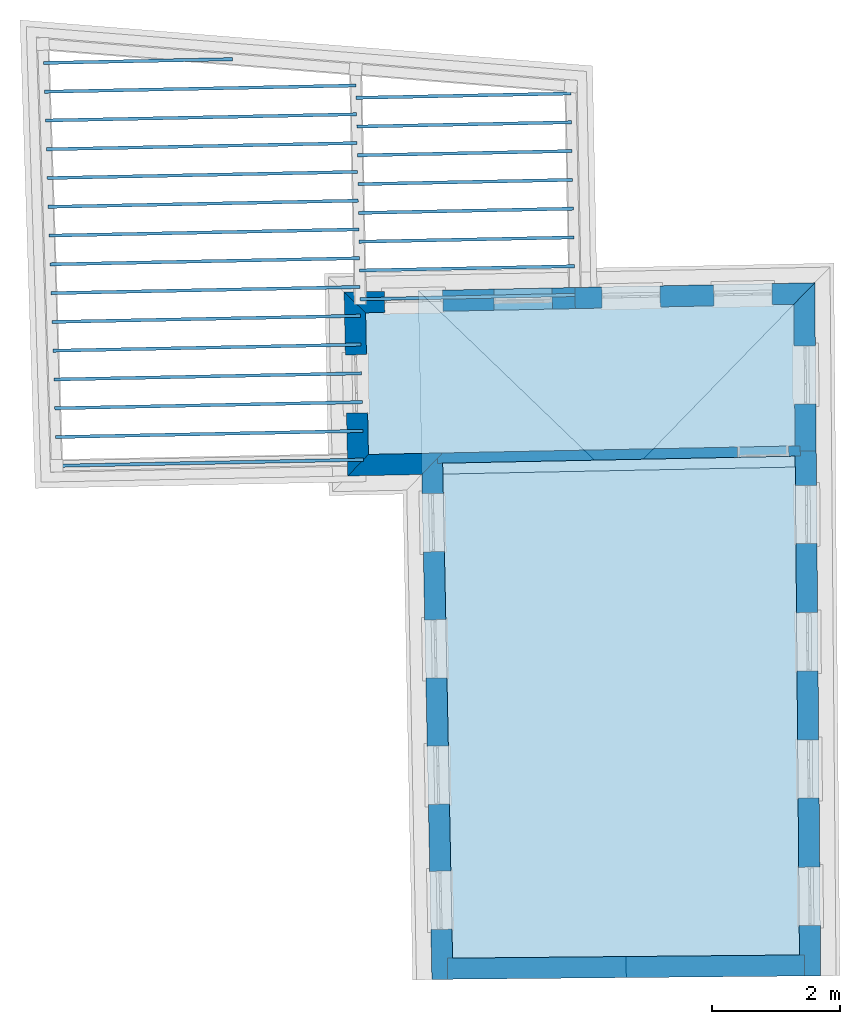
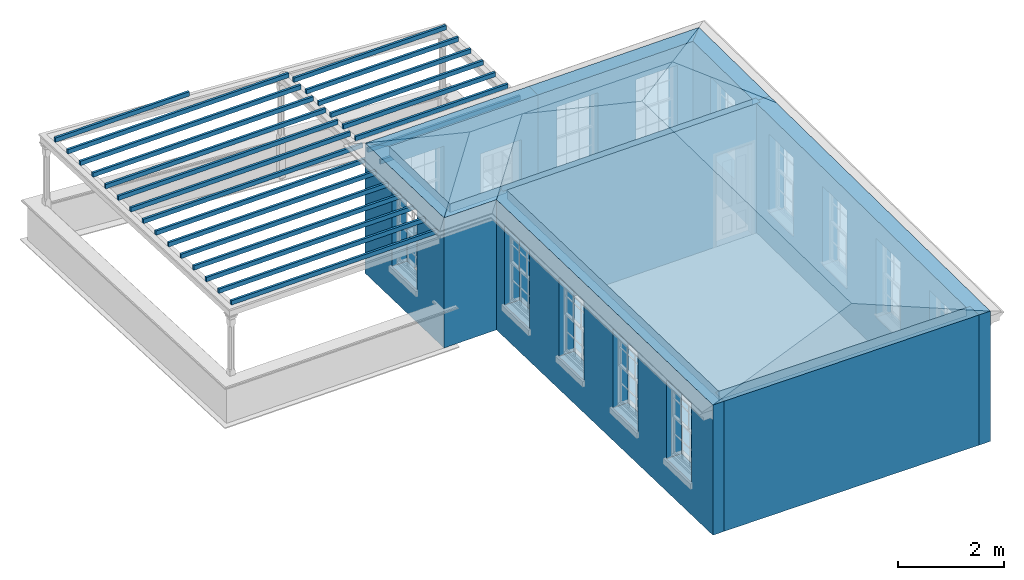
# One storey, part 1 of 11: 26 slabs, 9 walls, 2 roofs, 15 openings.
"""IFC2X3 building model written with IfcOpenShell, lengths in metres."""

from ifc_helpers import new_model, si_unit, frame, origin, place, context, subcontext, project, spatial, polyline, outline, extrude, faceted_brep, material, layer, layer_set, layer_usage, element, save


model = new_model("IFC2X3")

# Units and contexts
model_context = context("Model", 3, world=origin())
body_context = subcontext(model_context, "Body", "Model", "MODEL_VIEW")
ifc_project = project(units=[si_unit("PLANEANGLEUNIT", "RADIAN"), si_unit("MASSUNIT", "GRAM", prefix="KILO"), si_unit("FORCEUNIT", "NEWTON", prefix="KILO"), si_unit("LENGTHUNIT", "METRE")], contexts=[model_context])

# Site, building, storey
site_placement = place(None, origin())
site = spatial("IfcSite", under=ifc_project, at=site_placement, CompositionType="ELEMENT")
building_placement = place(None, origin())
building = spatial("IfcBuilding", under=site, at=building_placement, Name="Building plot-11", CompositionType="ELEMENT")
storey_placement = place(None, frame((0.0, 0.0, 5.3)))
storey = spatial("IfcBuildingStorey", under=building, at=storey_placement, Name="Floor 1", CompositionType="ELEMENT", Elevation=5.3)

# Slabs
slab_1_placement = place(storey_placement, frame((0.0, 0.0, 2.5)))
element("IfcSlab", 1, at=slab_1_placement, inside=storey, Name="Slab", ObjectType="Slab", PredefinedType="FLOOR", context=body_context, shape_type="SweptSolid", body=[
    extrude(outline(polyline([(58.6521226222642, 25.9709667040355), (58.6531222515861, 25.920976697622), (62.0106895836029, 25.9881165720905), (62.009689954281, 26.038106578504), (58.6521226222642, 25.9709667040355)])), origin(), (0.0, 0.0, 1.0), 0.1),
])
slab_2_placement = place(storey_placement, frame((0.0, 0.0, 2.5)))
element("IfcSlab", 2, at=slab_2_placement, inside=storey, Name="Slab", ObjectType="Slab", PredefinedType="FLOOR", context=body_context, shape_type="SweptSolid", body=[
    extrude(outline(polyline([(58.6611192861611, 25.5210566463143), (58.662118915483, 25.4710666399008), (62.0196862474998, 25.5382065143693), (62.018686618178, 25.5881965207827), (58.6611192861611, 25.5210566463143)])), origin(), (0.0, 0.0, 1.0), 0.1),
])
slab_3_placement = place(storey_placement, frame((0.0, 0.0, 2.5)))
element("IfcSlab", 3, at=slab_3_placement, inside=storey, Name="Slab", ObjectType="Slab", PredefinedType="FLOOR", context=body_context, shape_type="SweptSolid", body=[
    extrude(outline(polyline([(58.6701159500581, 25.071146588593), (58.67111557938, 25.0211565821796), (62.0286829113968, 25.088296456648), (62.0276832820749, 25.1382864630615), (58.6701159500581, 25.071146588593)])), origin(), (0.0, 0.0, 1.0), 0.1),
])
slab_4_placement = place(storey_placement, frame((0.0, 0.0, 2.5)))
element("IfcSlab", 4, at=slab_4_placement, inside=storey, Name="Slab", ObjectType="Slab", PredefinedType="FLOOR", context=body_context, shape_type="SweptSolid", body=[
    extrude(outline(polyline([(58.679112613955, 24.6212365308718), (58.6801122432769, 24.5712465244583), (62.0376795752937, 24.6383863989268), (62.0366799459718, 24.6883764053403), (58.679112613955, 24.6212365308718)])), origin(), (0.0, 0.0, 1.0), 0.1),
])
slab_5_placement = place(storey_placement, frame((0.0, 0.0, 2.5)))
element("IfcSlab", 5, at=slab_5_placement, inside=storey, Name="Slab", ObjectType="Slab", PredefinedType="FLOOR", context=body_context, shape_type="SweptSolid", body=[
    extrude(outline(polyline([(58.688109277852, 24.1713264731506), (58.6891089071738, 24.1213364667371), (62.0466762391907, 24.1884763412056), (62.0456766098688, 24.238466347619), (58.688109277852, 24.1713264731506)])), origin(), (0.0, 0.0, 1.0), 0.1),
])
slab_6_placement = place(storey_placement, frame((0.0, 0.0, 2.5)))
element("IfcSlab", 6, at=slab_6_placement, inside=storey, Name="Slab", ObjectType="Slab", PredefinedType="FLOOR", context=body_context, shape_type="SweptSolid", body=[
    extrude(outline(polyline([(58.6971059417489, 23.7214164154293), (58.6981055710708, 23.6714264090159), (62.0556729030876, 23.7385662834843), (62.0546732737657, 23.7885562898978), (58.6971059417489, 23.7214164154293)])), origin(), (0.0, 0.0, 1.0), 0.1),
])
slab_7_placement = place(storey_placement, frame((0.0, 0.0, 2.5)))
element("IfcSlab", 7, at=slab_7_placement, inside=storey, Name="Slab", ObjectType="Slab", PredefinedType="FLOOR", context=body_context, shape_type="SweptSolid", body=[
    extrude(outline(polyline([(58.7061026056458, 23.2715063577081), (58.7071022349677, 23.2215163512946), (62.0646695669845, 23.2886562257631), (62.0636699376626, 23.3386462321766), (58.7061026056458, 23.2715063577081)])), origin(), (0.0, 0.0, 1.0), 0.1),
])
slab_8_placement = place(storey_placement, frame((0.0, 0.0, 2.5)))
element("IfcSlab", 8, at=slab_8_placement, inside=storey, Name="Slab", ObjectType="Slab", PredefinedType="FLOOR", context=body_context, shape_type="SweptSolid", body=[
    extrude(outline(polyline([(58.7150992695428, 22.8215962999869), (58.7160988988647, 22.7716062935734), (62.0736662308815, 22.8387461680419), (62.0726666015596, 22.8887361744553), (58.7150992695428, 22.8215962999869)])), origin(), (0.0, 0.0, 1.0), 0.1),
])
slab_9_placement = place(storey_placement, frame((0.0, 0.0, 2.8)))
element("IfcSlab", 9, at=slab_9_placement, inside=storey, Name="Slab", ObjectType="Slab", PredefinedType="FLOOR", context=body_context, shape_type="SweptSolid", body=[
    extrude(outline(polyline([(60.0045068088398, 20.2339934819593), (60.1592055257371, 12.4977359707286), (65.5809351272987, 12.5479233995092), (65.5141481364612, 20.3441674831101), (60.0045068088398, 20.2339934819593)])), origin(), (0.0, 0.0, 1.0), 0.2),
])
slab_10_placement = place(storey_placement, frame((0.0, 0.0, 2.8)))
element("IfcSlab", 10, at=slab_10_placement, inside=storey, Name="Slab", ObjectType="Slab", PredefinedType="FLOOR", context=body_context, shape_type="SweptSolid", body=[
    extrude(outline(polyline([(58.7998507375589, 22.5847820884662), (58.8441223797636, 20.3708217440617), (65.5127774476926, 20.5041720598883), (65.4938070899396, 22.718638343531), (58.7998507375589, 22.5847820884662)])), origin(), (0.0, 0.0, 1.0), 0.2),
])
slab_11_placement = place(storey_placement, frame((0.0, 0.0, 2.5)))
element("IfcSlab", 11, at=slab_11_placement, inside=storey, Name="Slab", ObjectType="Slab", PredefinedType="FLOOR", context=body_context, shape_type="SweptSolid", body=[
    extrude(outline(polyline([(58.766237591078, 20.2642433236783), (58.7652379617561, 20.3142333300917), (53.9692989539135, 20.2183309367504), (53.9702985832353, 20.1683409303369), (58.766237591078, 20.2642433236783)])), origin(), (0.0, 0.0, 1.0), 0.1),
])
slab_12_placement = place(storey_placement, frame((0.0, 0.0, 2.5)))
element("IfcSlab", 12, at=slab_12_placement, inside=storey, Name="Slab", ObjectType="Slab", PredefinedType="FLOOR", context=body_context, shape_type="SweptSolid", body=[
    extrude(outline(polyline([(58.7572409271811, 20.7141533813995), (58.7562412978592, 20.764143387813), (53.9546451630597, 20.6681278712619), (53.9556447923816, 20.6181378648484), (58.7572409271811, 20.7141533813995)])), origin(), (0.0, 0.0, 1.0), 0.1),
])
slab_13_placement = place(storey_placement, frame((0.0, 0.0, 2.5)))
element("IfcSlab", 13, at=slab_13_placement, inside=storey, Name="Slab", ObjectType="Slab", PredefinedType="FLOOR", context=body_context, shape_type="SweptSolid", body=[
    extrude(outline(polyline([(58.7482442632841, 21.1640634391207), (58.7472446339623, 21.2140534455342), (53.939991372206, 21.1179248057733), (53.9409910015278, 21.0679347993598), (58.7482442632841, 21.1640634391207)])), origin(), (0.0, 0.0, 1.0), 0.1),
])
slab_14_placement = place(storey_placement, frame((0.0, 0.0, 2.5)))
element("IfcSlab", 14, at=slab_14_placement, inside=storey, Name="Slab", ObjectType="Slab", PredefinedType="FLOOR", context=body_context, shape_type="SweptSolid", body=[
    extrude(outline(polyline([(58.7392475993872, 21.613973496842), (58.7382479700653, 21.6639635032554), (53.9253375813522, 21.5677217402847), (53.9263372106741, 21.5177317338712), (58.7392475993872, 21.613973496842)])), origin(), (0.0, 0.0, 1.0), 0.1),
])
slab_15_placement = place(storey_placement, frame((0.0, 0.0, 2.5)))
element("IfcSlab", 15, at=slab_15_placement, inside=storey, Name="Slab", ObjectType="Slab", PredefinedType="FLOOR", context=body_context, shape_type="SweptSolid", body=[
    extrude(outline(polyline([(58.7302509354903, 22.0638835545632), (58.7292513061684, 22.1138735609767), (53.9106837904985, 22.0175186747961), (53.9116834198203, 21.9675286683827), (58.7302509354903, 22.0638835545632)])), origin(), (0.0, 0.0, 1.0), 0.1),
])
slab_16_placement = place(storey_placement, frame((0.0, 0.0, 2.5)))
element("IfcSlab", 16, at=slab_16_placement, inside=storey, Name="Slab", ObjectType="Slab", PredefinedType="FLOOR", context=body_context, shape_type="SweptSolid", body=[
    extrude(outline(polyline([(58.7212542715933, 22.5137936122844), (58.7202546422714, 22.5637836186979), (53.8960299996447, 22.4673156093076), (53.8970296289666, 22.4173256028941), (58.7212542715933, 22.5137936122844)])), origin(), (0.0, 0.0, 1.0), 0.1),
])
slab_17_placement = place(storey_placement, frame((0.0, 0.0, 2.5)))
element("IfcSlab", 17, at=slab_17_placement, inside=storey, Name="Slab", ObjectType="Slab", PredefinedType="FLOOR", context=body_context, shape_type="SweptSolid", body=[
    extrude(outline(polyline([(58.7122576076964, 22.9637036700057), (58.7112579783745, 23.0136936764191), (53.881376208791, 22.917112543819), (53.8823758381128, 22.8671225374055), (58.7122576076964, 22.9637036700057)])), origin(), (0.0, 0.0, 1.0), 0.1),
])
slab_18_placement = place(storey_placement, frame((0.0, 0.0, 2.5)))
element("IfcSlab", 18, at=slab_18_placement, inside=storey, Name="Slab", ObjectType="Slab", PredefinedType="FLOOR", context=body_context, shape_type="SweptSolid", body=[
    extrude(outline(polyline([(58.7032609437994, 23.4136137277269), (58.7022613144776, 23.4636037341404), (53.8667224179372, 23.3669094783304), (53.8677220472591, 23.316919471917), (58.7032609437994, 23.4136137277269)])), origin(), (0.0, 0.0, 1.0), 0.1),
])
slab_19_placement = place(storey_placement, frame((0.0, 0.0, 2.5)))
element("IfcSlab", 19, at=slab_19_placement, inside=storey, Name="Slab", ObjectType="Slab", PredefinedType="FLOOR", context=body_context, shape_type="SweptSolid", body=[
    extrude(outline(polyline([(58.6942642799025, 23.8635237854481), (58.6932646505806, 23.9135137918616), (53.8520686270835, 23.8167064128419), (53.8530682564053, 23.7667164064284), (58.6942642799025, 23.8635237854481)])), origin(), (0.0, 0.0, 1.0), 0.1),
])
slab_20_placement = place(storey_placement, frame((0.0, 0.0, 2.5)))
element("IfcSlab", 20, at=slab_20_placement, inside=storey, Name="Slab", ObjectType="Slab", PredefinedType="FLOOR", context=body_context, shape_type="SweptSolid", body=[
    extrude(outline(polyline([(58.6852676160056, 24.3134338431694), (58.6842679866837, 24.3634238495829), (53.8374148362297, 24.2665033473533), (53.8384144655516, 24.2165133409398), (58.6852676160056, 24.3134338431694)])), origin(), (0.0, 0.0, 1.0), 0.1),
])
slab_21_placement = place(storey_placement, frame((0.0, 0.0, 2.5)))
element("IfcSlab", 21, at=slab_21_placement, inside=storey, Name="Slab", ObjectType="Slab", PredefinedType="FLOOR", context=body_context, shape_type="SweptSolid", body=[
    extrude(outline(polyline([(58.6762709521086, 24.7633439008906), (58.6752713227867, 24.8133339073041), (53.822761045376, 24.7163002818647), (53.8237606746978, 24.6663102754513), (58.6762709521086, 24.7633439008906)])), origin(), (0.0, 0.0, 1.0), 0.1),
])
slab_22_placement = place(storey_placement, frame((0.0, 0.0, 2.5)))
element("IfcSlab", 22, at=slab_22_placement, inside=storey, Name="Slab", ObjectType="Slab", PredefinedType="FLOOR", context=body_context, shape_type="SweptSolid", body=[
    extrude(outline(polyline([(58.6672742882117, 25.2132539586119), (58.6662746588898, 25.2632439650253), (53.8081072545222, 25.1660972163762), (53.8091068838441, 25.1161072099627), (58.6672742882117, 25.2132539586119)])), origin(), (0.0, 0.0, 1.0), 0.1),
])
slab_23_placement = place(storey_placement, frame((0.0, 0.0, 2.5)))
element("IfcSlab", 23, at=slab_23_placement, inside=storey, Name="Slab", ObjectType="Slab", PredefinedType="FLOOR", context=body_context, shape_type="SweptSolid", body=[
    extrude(outline(polyline([(58.6582776243147, 25.6631640163331), (58.6572779949929, 25.7131540227466), (53.7934534636684, 25.6158941508876), (53.7944530929903, 25.5659041444741), (58.6582776243147, 25.6631640163331)])), origin(), (0.0, 0.0, 1.0), 0.1),
])
slab_24_placement = place(storey_placement, frame((0.0, 0.0, 2.5)))
element("IfcSlab", 24, at=slab_24_placement, inside=storey, Name="Slab", ObjectType="Slab", PredefinedType="FLOOR", context=body_context, shape_type="SweptSolid", body=[
    extrude(outline(polyline([(58.6492809604178, 26.1130740740543), (58.6482813310959, 26.1630640804678), (53.7787996728147, 26.065691085399), (53.7797993021366, 26.0157010789856), (58.6492809604178, 26.1130740740543)])), origin(), (0.0, 0.0, 1.0), 0.1),
])
slab_25_placement = place(storey_placement, frame((0.0, 0.0, 2.5)))
element("IfcSlab", 25, at=slab_25_placement, inside=storey, Name="Slab", ObjectType="Slab", PredefinedType="FLOOR", context=body_context, shape_type="SweptSolid", body=[
    extrude(outline(polyline([(56.7230668072718, 26.5246463327597), (56.72206717795, 26.5746363391732), (53.7641458819609, 26.5154880199105), (53.7651455112828, 26.465498013497), (56.7230668072718, 26.5246463327597)])), origin(), (0.0, 0.0, 1.0), 0.1),
])
slab_26_placement = place(storey_placement, origin())
element("IfcSlab", 26, at=slab_26_placement, inside=storey, Name="Slab", ObjectType="Slab", PredefinedType="FLOOR", context=body_context, shape_type="SweptSolid", body=[
    extrude(outline(polyline([(60.0045068088398, 20.2339934819593), (60.1592055257371, 12.4977359707286), (65.5809351272987, 12.5479233995092), (65.5141481364612, 20.3441674831101), (60.0045068088398, 20.2339934819593)])), origin(), (0.0, 0.0, 1.0), 0.02),
])

# Wall, openings
ifc_material_1 = material(Name="Masonry")
ifc_layer_1 = layer(ifc_material_1, 0.33, ventilated=False)
ifc_layer_set_1 = layer_set([ifc_layer_1], Name="My Wall")
ifc_layer_usage_1 = layer_usage(ifc_layer_set_1, "AXIS2", "NEGATIVE", 0.08)
wall_1_placement = place(storey_placement, origin())
wall_1 = element("IfcWallStandardCase", 27, at=wall_1_placement, inside=storey, material=ifc_layer_usage_1, Name="exterior", context=body_context, shape_type="SweptSolid", body=[
    extrude(outline(polyline([(65.5837615155297, 12.2179906948306), (65.913749407515, 12.220817555827), (65.8434428524129, 20.4279108442136), (65.5134549604276, 20.4250839832172), (65.5837615155297, 12.2179906948306)])), origin(), (0.0, 0.0, 1.0), 3.0),
])
opening_1_placement = place(storey_placement, frame((0.0, 0.0, 0.75)))
element("IfcOpeningElement", 28, at=opening_1_placement, cuts=wall_1, Name="Opening", ObjectType="Opening", context=body_context, shape_type="SweptSolid", body=[
    extrude(outline(polyline([(65.9069848636133, 13.0104628851131), (65.8991895802596, 13.9204294963454), (65.5692016882743, 13.9176026353489), (65.576996971628, 13.0076360241167), (65.9069848636133, 13.0104628851131)])), origin(), (0.0, 0.0, 1.0), 1.82),
])
opening_2_placement = place(storey_placement, frame((0.0, 0.0, 0.75)))
element("IfcOpeningElement", 29, at=opening_2_placement, cuts=wall_1, Name="Opening", ObjectType="Opening", context=body_context, shape_type="SweptSolid", body=[
    extrude(outline(polyline([(65.889943615178, 14.9997385003944), (65.8821483318243, 15.9097051116266), (65.552160439839, 15.9068782506302), (65.5599557231927, 14.996911639398), (65.889943615178, 14.9997385003944)])), origin(), (0.0, 0.0, 1.0), 1.82),
])
opening_3_placement = place(storey_placement, frame((0.0, 0.0, 0.75)))
element("IfcOpeningElement", 30, at=opening_3_placement, cuts=wall_1, Name="Opening", ObjectType="Opening", context=body_context, shape_type="SweptSolid", body=[
    extrude(outline(polyline([(65.8729023667427, 16.9890141156756), (65.865107083389, 17.8989807269079), (65.5351191914037, 17.8961538659114), (65.5429144747574, 16.9861872546792), (65.8729023667427, 16.9890141156756)])), origin(), (0.0, 0.0, 1.0), 1.82),
])
opening_4_placement = place(storey_placement, frame((0.0, 0.0, 0.75)))
element("IfcOpeningElement", 31, at=opening_4_placement, cuts=wall_1, Name="Opening", ObjectType="Opening", context=body_context, shape_type="SweptSolid", body=[
    extrude(outline(polyline([(65.8558611183074, 18.9782897309569), (65.8480658349537, 19.8882563421891), (65.5180779429683, 19.8854294811927), (65.5258732263221, 18.9754628699605), (65.8558611183074, 18.9782897309569)])), origin(), (0.0, 0.0, 1.0), 1.82),
])

# Wall, opening
wall_2_placement = place(storey_placement, origin())
wall_2 = element("IfcWallStandardCase", 32, at=wall_2_placement, inside=storey, material=ifc_layer_usage_1, Name="exterior", context=body_context, shape_type="SweptSolid", body=[
    extrude(outline(polyline([(65.5134549604276, 20.4250839832172), (65.8434428524129, 20.4279108442136), (65.820935630786, 23.0552457674694), (65.4938070899396, 22.718638343531), (65.5134549604276, 20.4250839832172)])), origin(), (0.0, 0.0, 1.0), 3.0),
])
opening_5_placement = place(storey_placement, frame((0.0, 0.0, 0.75)))
element("IfcOpeningElement", 33, at=opening_5_placement, cuts=wall_2, Name="Opening", ObjectType="Opening", context=body_context, shape_type="SweptSolid", body=[
    extrude(outline(polyline([(65.8371699708289, 21.1601629688085), (65.8293746874752, 22.0701295800407), (65.4993867954899, 22.0673027190443), (65.5071820788436, 21.157336107812), (65.8371699708289, 21.1601629688085)])), origin(), (0.0, 0.0, 1.0), 1.82),
])

# Wall, openings
wall_3_placement = place(storey_placement, origin())
wall_3 = element("IfcWallStandardCase", 34, at=wall_3_placement, inside=storey, material=ifc_layer_usage_1, Name="exterior", context=body_context, shape_type="SweptSolid", body=[
    extrude(outline(polyline([(65.4938070899396, 22.718638343531), (65.820935630786, 23.0552457674694), (62.0708365057897, 22.9802565983485), (62.0774340593141, 22.6503225560195), (65.4938070899396, 22.718638343531)])), origin(), (0.0, 0.0, 1.0), 3.0),
])
opening_6_placement = place(storey_placement, frame((0.0, 0.0, 0.75)))
element("IfcOpeningElement", 35, at=opening_6_placement, cuts=wall_3, Name="Opening", ObjectType="Opening", context=body_context, shape_type="SweptSolid", body=[
    extrude(outline(polyline([(65.1487028088251, 23.0418034079227), (64.2388846921, 23.0236101542645), (64.2454822456244, 22.6936761119355), (65.1553003623496, 22.7118693655938), (65.1487028088251, 23.0418034079227)])), origin(), (0.0, 0.0, 1.0), 1.82),
])
opening_7_placement = place(storey_placement, frame((0.0, 0.0, 0.75)))
element("IfcOpeningElement", 36, at=opening_7_placement, cuts=wall_3, Name="Opening", ObjectType="Opening", context=body_context, shape_type="SweptSolid", body=[
    extrude(outline(polyline([(63.4000646457099, 23.006836619426), (62.4902465289847, 22.9886433657677), (62.4968440825092, 22.6587093234388), (63.4066621992343, 22.676902577097), (63.4000646457099, 23.006836619426)])), origin(), (0.0, 0.0, 1.0), 1.82),
])

wall_4_placement = place(storey_placement, origin())
wall_4 = element("IfcWallStandardCase", 37, at=wall_4_placement, inside=storey, material=ifc_layer_usage_1, Name="exterior", context=body_context, shape_type="SweptSolid", body=[
    extrude(outline(polyline([(62.0774340593141, 22.6503225560195), (62.0708365057897, 22.9802565983485), (58.4633191417055, 22.9081185772706), (58.7998507375589, 22.5847820884662), (62.0774340593141, 22.6503225560195)])), origin(), (0.0, 0.0, 1.0), 3.0),
])
opening_8_placement = place(storey_placement, frame((0.0, 0.0, 0.0199999999999996)))
element("IfcOpeningElement", 38, at=opening_8_placement, cuts=wall_4, Name="Opening", ObjectType="Opening", context=body_context, shape_type="SweptSolid", body=[
    extrude(outline(polyline([(61.7126695585811, 22.9730944831929), (60.802851441856, 22.9549012295347), (60.8094489953804, 22.6249671872058), (61.7192671121056, 22.643160440864), (61.7126695585811, 22.9730944831929)])), origin(), (0.0, 0.0, 1.0), 2.08),
])
opening_9_placement = place(storey_placement, frame((0.0, 0.0, 0.75)))
element("IfcOpeningElement", 39, at=opening_9_placement, cuts=wall_4, Name="Opening", ObjectType="Opening", context=body_context, shape_type="SweptSolid", body=[
    extrude(outline(polyline([(60.0030113392404, 22.9389071603846), (59.0931932225153, 22.9207139067264), (59.0997907760397, 22.5907798643974), (60.0096088927649, 22.6089731180557), (60.0030113392404, 22.9389071603846)])), origin(), (0.0, 0.0, 1.0), 1.82),
])

# Wall, opening
wall_5_placement = place(storey_placement, origin())
wall_5 = element("IfcWallStandardCase", 40, at=wall_5_placement, inside=storey, material=ifc_layer_usage_1, Name="exterior", context=body_context, shape_type="SweptSolid", body=[
    extrude(outline(polyline([(58.7998507375589, 22.5847820884662), (58.4633191417055, 22.9081185772706), (58.5207858909592, 20.0342901482081), (58.8441223797636, 20.3708217440617), (58.7998507375589, 22.5847820884662)])), origin(), (0.0, 0.0, 1.0), 3.0),
])
opening_10_placement = place(storey_placement, frame((0.0, 0.0, 0.75)))
element("IfcOpeningElement", 41, at=opening_10_placement, cuts=wall_5, Name="Opening", ObjectType="Opening", context=body_context, shape_type="SweptSolid", body=[
    extrude(outline(polyline([(58.4829558895032, 21.926113421102), (58.5011491431615, 21.0162953043769), (58.8310831854904, 21.0228928579013), (58.8128899318321, 21.9327109746264), (58.4829558895032, 21.926113421102)])), origin(), (0.0, 0.0, 1.0), 1.82),
])

# Wall
wall_6_placement = place(storey_placement, origin())
element("IfcWallStandardCase", 42, at=wall_6_placement, inside=storey, material=ifc_layer_usage_1, Name="exterior", context=body_context, shape_type="SweptSolid", body=[
    extrude(outline(polyline([(58.8441223797636, 20.3708217440617), (58.5207858909592, 20.0342901482081), (59.6779715062053, 20.057429906629), (60.0013079950097, 20.3939615024824), (58.8441223797636, 20.3708217440617)])), origin(), (0.0, 0.0, 1.0), 3.0),
])

# Wall, openings
wall_7_placement = place(storey_placement, origin())
wall_7 = element("IfcWallStandardCase", 43, at=wall_7_placement, inside=storey, material=ifc_layer_usage_1, Name="exterior", context=body_context, shape_type="SweptSolid", body=[
    extrude(outline(polyline([(60.0013079950097, 20.3939615024824), (59.6779715062053, 20.057429906629), (59.8358519549038, 12.1620586222609), (60.1657859972327, 12.1686561757854), (60.0013079950097, 20.3939615024824)])), origin(), (0.0, 0.0, 1.0), 3.0),
])
opening_11_placement = place(storey_placement, frame((0.0, 0.0, 0.75)))
element("IfcOpeningElement", 44, at=opening_11_placement, cuts=wall_7, Name="Opening", ObjectType="Opening", context=body_context, shape_type="SweptSolid", body=[
    extrude(outline(polyline([(59.6839692821365, 19.7574898681482), (59.7021625357948, 18.847671751423), (60.0320965781237, 18.8542693049475), (60.0139033244655, 19.7640874216726), (59.6839692821365, 19.7574898681482)])), origin(), (0.0, 0.0, 1.0), 1.82),
])
opening_12_placement = place(storey_placement, frame((0.0, 0.0, 0.75)))
element("IfcOpeningElement", 45, at=opening_12_placement, cuts=wall_7, Name="Opening", ObjectType="Opening", context=body_context, shape_type="SweptSolid", body=[
    extrude(outline(polyline([(59.7234393943112, 17.7836470470562), (59.7416326479694, 16.873828930331), (60.0715666902983, 16.8804264838554), (60.0533734366401, 17.7902446005806), (59.7234393943112, 17.7836470470562)])), origin(), (0.0, 0.0, 1.0), 1.82),
])
opening_13_placement = place(storey_placement, frame((0.0, 0.0, 0.75)))
element("IfcOpeningElement", 46, at=opening_13_placement, cuts=wall_7, Name="Opening", ObjectType="Opening", context=body_context, shape_type="SweptSolid", body=[
    extrude(outline(polyline([(59.7629095064858, 15.8098042259642), (59.7811027601441, 14.899986109239), (60.111036802473, 14.9065836627634), (60.0928435488147, 15.8164017794886), (59.7629095064858, 15.8098042259642)])), origin(), (0.0, 0.0, 1.0), 1.82),
])
opening_14_placement = place(storey_placement, frame((0.0, 0.0, 0.75)))
element("IfcOpeningElement", 47, at=opening_14_placement, cuts=wall_7, Name="Opening", ObjectType="Opening", context=body_context, shape_type="SweptSolid", body=[
    extrude(outline(polyline([(59.8020221253779, 13.8538391232369), (59.8202153790362, 12.9440210065117), (60.1501494213651, 12.9506185600361), (60.1319561677068, 13.8604366767613), (59.8020221253779, 13.8538391232369)])), origin(), (0.0, 0.0, 1.0), 1.82),
])

# Wall
wall_8_placement = place(storey_placement, origin())
element("IfcWallStandardCase", 48, at=wall_8_placement, inside=storey, material=ifc_layer_usage_1, Name="party", context=body_context, shape_type="SweptSolid", body=[
    extrude(outline(polyline([(60.0800633345467, 12.4970033736839), (60.0831179210336, 12.1670175111058), (65.6639310995644, 12.2186775318958), (65.6608765130775, 12.5486633944739), (60.0800633345467, 12.4970033736839)])), origin(), (0.0, 0.0, 1.0), 3.0),
])

# Wall, opening
ifc_material_2 = material(Name="Masonry")
ifc_layer_2 = layer(ifc_material_2, 0.16, ventilated=False)
ifc_layer_set_2 = layer_set([ifc_layer_2], Name="My Wall")
ifc_layer_usage_2 = layer_usage(ifc_layer_set_2, "AXIS2", "NEGATIVE", 0.08)
wall_9_placement = place(storey_placement, origin())
wall_9 = element("IfcWallStandardCase", 49, at=wall_9_placement, inside=storey, material=ifc_layer_usage_2, Name="interior", context=body_context, shape_type="SweptSolid", body=[
    extrude(outline(polyline([(65.5950514320663, 20.3457852725911), (65.5918526182363, 20.5057532931143), (59.9213239847482, 20.3923620955674), (59.9245227985782, 20.2323940750442), (65.5950514320663, 20.3457852725911)])), origin(), (0.0, 0.0, 1.0), 3.0),
])
opening_15_placement = place(storey_placement, frame((0.0, 0.0, 0.0199999999999996)))
element("IfcOpeningElement", 50, at=opening_15_placement, cuts=wall_9, Name="Opening", ObjectType="Opening", context=body_context, shape_type="SweptSolid", body=[
    extrude(outline(polyline([(65.4118885951478, 20.5021546275555), (64.6120484925323, 20.4861605584054), (64.6152473063623, 20.3261925378823), (65.4150874089778, 20.3421866070324), (65.4118885951478, 20.5021546275555)])), origin(), (0.0, 0.0, 1.0), 2.1),
])

# Roofs
roof_1_placement = place(building_placement, origin())
element("IfcRoof", 51, at=roof_1_placement, inside=storey, Name="Roof", ShapeType="FREEFORM", context=body_context, shape_type="Brep", held_by="IfcProductRepresentation", body=[
    faceted_brep([(59.620505, 22.931258, 8.3), (59.835799, 12.164728, 8.3), (62.87486, 12.19286, 9.558802), (62.764646, 19.910397, 9.577069), (65.913748, 12.22099, 8.3), (65.820936, 23.055246, 8.3)], [[[0, 1, 2, 3]], [[4, 5, 3, 2]], [[5, 4, 1, 0]], [[5, 0, 3]], [[1, 4, 2]]]),
])
roof_2_placement = place(building_placement, origin())
element("IfcRoof", 52, at=roof_2_placement, inside=storey, Name="Roof", ShapeType="FREEFORM", context=body_context, shape_type="Brep", held_by="IfcProductRepresentation", body=[
    faceted_brep([(58.520786, 20.03429, 8.3), (65.84556, 20.180761, 8.3), (64.39624, 21.589268, 8.895308), (59.928967, 21.499938, 8.895308), (65.820936, 23.055246, 8.3), (58.463319, 22.908119, 8.3)], [[[0, 1, 2, 3]], [[4, 5, 3, 2]], [[5, 4, 1, 0]], [[5, 0, 3]], [[1, 4, 2]]]),
])

save(model, "model.ifc")
